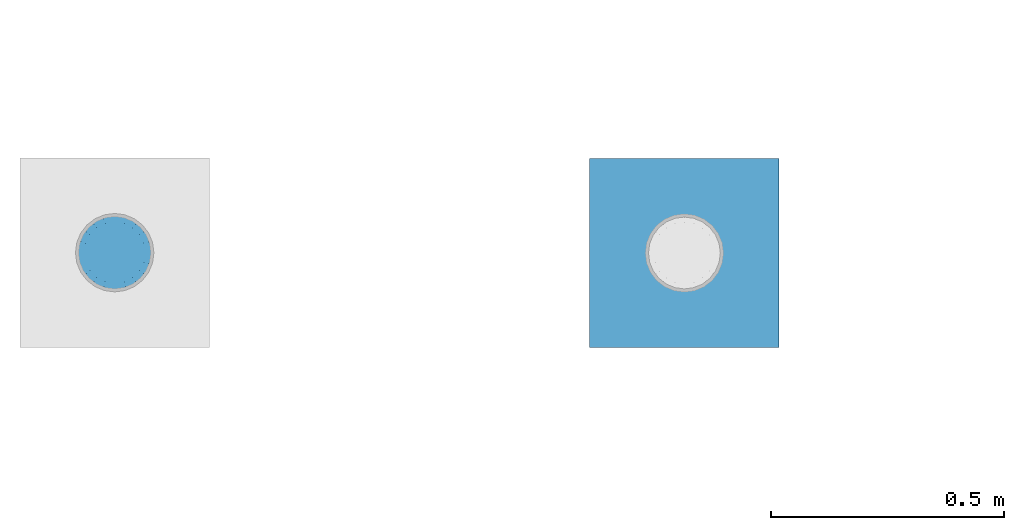
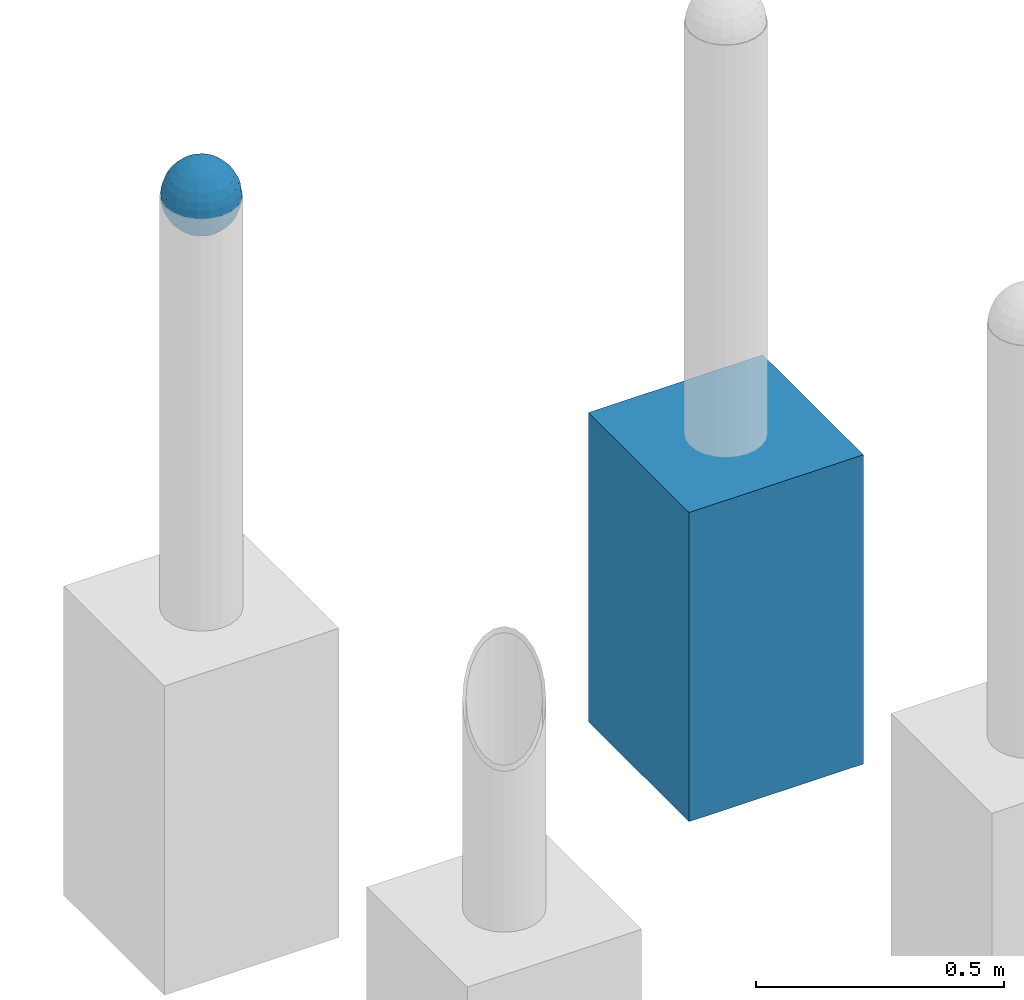
# One storey, part 1434 of 3843: 2 columns, 2 elements without a shape of their own.
"""IFC2X3 building model written with IfcOpenShell, lengths in millimetres."""

import ifcopenshell
import ifcopenshell.guid

model = None  # the IFC model being written
_history = None  # IfcOwnerHistory: only IFC2X3 demands one
_inside = {}  # id of a spatial element -> (the spatial element, [elements in it])
_under = {}  # id of a project, library or spatial element -> (it, [spatial elements below it])
_declared = {}  # id of a project -> (the project, [libraries it declares])
_typed = {}  # id of a type object -> (the type object, [elements of that type])
_made_of = {}  # id of a material, layer set ... -> (it, [elements and type objects made of it])


def new_model(schema):
    """Start an empty IFC model of exactly this schema.

    Asked for "IFC4X3", IfcOpenShell would pick the latest addendum, in which some entities
    have other attributes; the version numbers below select the first issue.
    IFC2X3 requires an IfcOwnerHistory on every rooted entity: one is made here for all.
    """
    global model, _history
    if schema == "IFC4X3":
        model = ifcopenshell.file(schema_version=(4, 3, 0, 0))
    else:
        model = ifcopenshell.file(schema=schema)
    _inside.clear()
    _under.clear()
    _declared.clear()
    _typed.clear()
    _made_of.clear()
    _history = None
    if model.schema == "IFC2X3":
        org = make("IfcOrganization", Name="unknown")
        user = make(
            "IfcPersonAndOrganization",
            ThePerson=make("IfcPerson", FamilyName="unknown"),
            TheOrganization=org,
        )
        app = make(
            "IfcApplication",
            ApplicationDeveloper=org,
            Version="unknown",
            ApplicationFullName="unknown",
            ApplicationIdentifier="unknown",
        )
        _history = make(
            "IfcOwnerHistory",
            OwningUser=user,
            OwningApplication=app,
            ChangeAction="ADDED",
            CreationDate=0,
        )
    return model


def make(cls, **values):
    """One entity of the class cls with the attributes given. An attribute that is None is left unset."""
    return model.create_entity(
        cls, **{name: value for name, value in values.items() if value is not None}
    )


def rooted(cls, **values):
    """An entity with a GlobalId (a new one), such as an element, a storey or a relation."""
    return make(cls, GlobalId=ifcopenshell.guid.new(), OwnerHistory=_history, **values)


def si_unit(unit_type, name, prefix=None):
    """IfcSIUnit, for example si_unit("LENGTHUNIT", "METRE", prefix="MILLI")."""
    return make("IfcSIUnit", UnitType=unit_type, Prefix=prefix, Name=name)


def assignment(units):
    """IfcUnitAssignment: the units of a project."""
    return None if units is None else make("IfcUnitAssignment", Units=units)


def point(xyz):
    """IfcCartesianPoint."""
    return None if xyz is None else make("IfcCartesianPoint", Coordinates=xyz)


def direction(xyz):
    """IfcDirection."""
    return None if xyz is None else make("IfcDirection", DirectionRatios=xyz)


def frame(location, z_axis=None, x_axis=None):
    """IfcAxis2Placement3D, a coordinate frame: its origin and axes. An axis left out is left unset."""
    return make(
        "IfcAxis2Placement3D",
        Location=point(location),
        Axis=direction(z_axis),
        RefDirection=direction(x_axis),
    )


def origin_with_axes():
    """The frame at (0, 0, 0) with the z axis (0, 0, 1) and the x axis (1, 0, 0) written out."""
    return frame((0.0, 0.0, 0.0), z_axis=(0.0, 0.0, 1.0), x_axis=(1.0, 0.0, 0.0))


def place(relative_to, where):
    """IfcLocalPlacement: puts the frame where relative to a parent placement (None: the world)."""
    return make(
        "IfcLocalPlacement", PlacementRelTo=relative_to, RelativePlacement=where
    )


def context(
    kind, dimensions, precision=None, world=None, true_north=None, identifier=None
):
    """IfcGeometricRepresentationContext, for example the 3D "Model" context."""
    return make(
        "IfcGeometricRepresentationContext",
        ContextIdentifier=identifier,
        ContextType=kind,
        CoordinateSpaceDimension=dimensions,
        Precision=precision,
        WorldCoordinateSystem=world,
        TrueNorth=true_north,
    )


def subcontext(parent, identifier, kind, view, scale=None):
    """IfcGeometricRepresentationSubContext, for example "Body" below "Model"."""
    return make(
        "IfcGeometricRepresentationSubContext",
        ContextIdentifier=identifier,
        ContextType=kind,
        ParentContext=parent,
        TargetScale=scale,
        TargetView=view,
    )


def project(units=None, contexts=None):
    """IfcProject with its units and contexts."""
    return rooted(
        "IfcProject",
        Name="project",
        RepresentationContexts=contexts,
        UnitsInContext=assignment(units),
    )


def spatial(cls, under=None, at=None, **own):
    """A site, building, storey or space (cls), placed at a placement, below another one or the project."""
    s = rooted(cls, ObjectPlacement=at, **own)
    if under is not None:
        _under.setdefault(under.id(), (under, []))[1].append(s)
    return s


def faces_of(points, faces, orient=None, outer=None):
    """IfcFace entities. A face is a list of loops; a loop is a list of indices into points, from 0.

    orient and outer hold one flag for each loop. By default every Orientation is true, the
    first loop of a face is its IfcFaceOuterBound and the others are IfcFaceBound.
    """
    made = []
    for i, loops in enumerate(faces):
        bounds = []
        for j, loop in enumerate(loops):
            is_outer = j == 0 if outer is None else outer[i][j]
            bounds.append(
                make(
                    "IfcFaceOuterBound" if is_outer else "IfcFaceBound",
                    Bound=make("IfcPolyLoop", Polygon=[points[k] for k in loop]),
                    Orientation=True if orient is None else orient[i][j],
                )
            )
        made.append(make("IfcFace", Bounds=bounds))
    return made


def faceted_brep(points, faces, orient=None, outer=None, voids=None):
    """IfcFacetedBrep: a solid bounded by flat faces; with voids (closed shells), ...WithVoids."""
    shared = [point(p) for p in points]
    hull = make("IfcClosedShell", CfsFaces=faces_of(shared, faces, orient, outer))
    if voids is None:
        return make("IfcFacetedBrep", Outer=hull)
    return make(
        "IfcFacetedBrepWithVoids",
        Outer=hull,
        Voids=[
            make(cls, CfsFaces=faces_of(shared, fs, o, b)) for cls, fs, o, b in voids
        ],
    )


def shape(context_of_items, identifier, shape_type, items):
    """IfcShapeRepresentation: the items that make up one representation, for example the "Body"."""
    return make(
        "IfcShapeRepresentation",
        ContextOfItems=context_of_items,
        RepresentationIdentifier=identifier,
        RepresentationType=shape_type,
        Items=items,
    )


def material(Name=None, Category=None):
    """IfcMaterial."""
    return make("IfcMaterial", Name=Name, Category=Category)


def made_of(thing, what):
    """Note that an element or type object is made of a material, layer set ...; save() writes the relation."""
    if what is not None:
        _made_of.setdefault(what.id(), (what, []))[1].append(thing)
    return thing


def type_object(cls, material=None, **own):
    """A type object (cls), such as IfcWallType, which elements share."""
    return made_of(rooted(cls, **own), material)


def element(
    cls,
    number,
    at=None,
    inside=None,
    cuts=None,
    type_object=None,
    material=None,
    context=None,
    identifier="Body",
    shape_type=None,
    held_by="IfcProductDefinitionShape",
    body=None,
    shapes=None,
    **own,
):
    """One element of the class cls, such as IfcWall. Its Tag is "e" and its number.

    at: its placement. inside: the storey or other place that contains it. cuts: it is an
    opening in that element (IfcRelVoidsElement). A single representation is given by context,
    identifier, shape_type and body (its items); several are given by shapes. held_by: the class
    of the entity that holds the representations. save() writes the other relations.
    """
    e = rooted(cls, Tag="e%d" % number, ObjectPlacement=at, **own)
    if body is not None:
        shapes = [shape(context, identifier, shape_type, body)]
    if shapes is not None:
        e.Representation = make(held_by, Representations=shapes)
    if inside is not None:
        _inside.setdefault(inside.id(), (inside, []))[1].append(e)
    if cuts is not None:
        rooted(
            "IfcRelVoidsElement", RelatingBuildingElement=cuts, RelatedOpeningElement=e
        )
    if type_object is not None:
        _typed.setdefault(type_object.id(), (type_object, []))[1].append(e)
    return made_of(e, material)


def aggregate(whole, parts):
    """IfcRelAggregates: a whole, such as a stair, and the parts it consists of."""
    return rooted("IfcRelAggregates", RelatingObject=whole, RelatedObjects=parts)


def save(model, path):
    """Write the relations noted so far, then the file.

    IfcRelAggregates (storeys below a building ...), IfcRelContainedInSpatialStructure (elements
    in a storey), IfcRelDefinesByType, IfcRelAssociatesMaterial and IfcRelDeclares: one each for
    every whole, place, type object, material and project.
    """
    for whole, parts in _under.values():
        aggregate(whole, parts)
    for where, things in _inside.values():
        rooted(
            "IfcRelContainedInSpatialStructure",
            RelatedElements=things,
            RelatingStructure=where,
        )
    for kind, things in _typed.values():
        rooted("IfcRelDefinesByType", RelatedObjects=things, RelatingType=kind)
    for what, things in _made_of.values():
        rooted("IfcRelAssociatesMaterial", RelatedObjects=things, RelatingMaterial=what)
    for by, libraries in _declared.values():
        rooted("IfcRelDeclares", RelatingContext=by, RelatedDefinitions=libraries)
    model.write(path)


model = new_model("IFC2X3")

# Units and contexts
model_context = context("Model", 3, precision=1e-05, world=origin_with_axes())
body_context = subcontext(model_context, "Body", "Model", "MODEL_VIEW")
ifc_project = project(units=[si_unit("LENGTHUNIT", "METRE", prefix="MILLI"), si_unit("AREAUNIT", "SQUARE_METRE"), si_unit("VOLUMEUNIT", "CUBIC_METRE"), si_unit("MASSUNIT", "GRAM", prefix="KILO"), si_unit("TIMEUNIT", "SECOND"), si_unit("PLANEANGLEUNIT", "RADIAN"), si_unit("SOLIDANGLEUNIT", "STERADIAN"), si_unit("THERMODYNAMICTEMPERATUREUNIT", "DEGREE_CELSIUS"), si_unit("LUMINOUSINTENSITYUNIT", "LUMEN")], contexts=[model_context])

# Site, building, storey
site_placement = place(None, origin_with_axes())
site = spatial("IfcSite", under=ifc_project, at=site_placement, CompositionType="ELEMENT")
building_placement = place(site_placement, origin_with_axes())
building = spatial("IfcBuilding", under=site, at=building_placement, Name="Undefined", CompositionType="ELEMENT")
storey_placement = place(building_placement, origin_with_axes())
storey = spatial("IfcBuildingStorey", under=building, at=storey_placement, Name="Undefined", CompositionType="ELEMENT", Elevation=0.0)

# Assembly, column
assembly_1_placement = place(storey_placement, origin_with_axes())
assembly_1 = element("IfcElementAssembly", 1, at=assembly_1_placement, inside=storey, Name="CONC_COL.", AssemblyPlace="NOTDEFINED", PredefinedType="REINFORCEMENT_UNIT")
ifc_material_1 = material(Name="CONCRETE/3000")
column_type_1 = type_object("IfcColumnType", PredefinedType="NOTDEFINED")
column_1_placement = place(assembly_1_placement, frame((-49323.3890688121, 17455.2500917911, 29718.0), z_axis=(-1.0, 0.0, 0.0), x_axis=(0.0, 0.0, 1.0)))
column_1 = element("IfcColumn", 2, at=column_1_placement, type_object=column_type_1, material=ifc_material_1, Name="CONC_COL.", context=body_context, shape_type="Brep", body=[
    faceted_brep([(0.0, 203.199999999997, -203.200000000001), (0.0, 203.199999999997, 203.200000000001), (762.0, 203.199999999997, 203.200000000001), (762.0, 203.199999999997, -203.200000000001), (0.0, -203.199999999997, 203.200000000001), (762.0, -203.199999999997, 203.200000000001), (0.0, -203.199999999997, -203.200000000001), (762.0, -203.199999999997, -203.200000000001)], [[[0, 1, 2, 3]], [[1, 4, 5, 2]], [[4, 6, 7, 5]], [[6, 0, 3, 7]], [[5, 7, 3, 2]], [[6, 4, 1, 0]]]),
])
aggregate(assembly_1, [column_1])

assembly_2_placement = place(storey_placement, origin_with_axes())
assembly_2 = element("IfcElementAssembly", 3, at=assembly_2_placement, inside=storey, Name="CONC. FILL", AssemblyPlace="NOTDEFINED", PredefinedType="REINFORCEMENT_UNIT")
ifc_material_2 = material(Name="CONCRETE/1500")
column_type_2 = type_object("IfcColumnType", PredefinedType="NOTDEFINED")
column_2_placement = place(assembly_2_placement, frame((-50545.9919130504, 17455.9024050236, 31411.8625), z_axis=(-1.0, 0.0, 0.0), x_axis=(0.0, 0.0, 1.0)))
column_2 = element("IfcColumn", 4, at=column_2_placement, type_object=column_type_2, material=ifc_material_2, Name="CONC. FILL", context=body_context, shape_type="Brep", body=[
    faceted_brep([(0.0, 0.0, 2.0), (0.0, -0.619999999995343, 1.89999999999964), (3.36549999999988, -7.1422259999963, 21.9814139999999), (3.36549999999988, 0.0, 23.1139999999996), (0.0, -1.17999999999302, 1.6200000000008), (3.36549999999988, -13.5910319999966, 18.6992260000006), (0.0, -1.61999999999534, 1.18000000000029), (3.36549999999988, -18.699225999997, 13.5910320000003), (0.0, -1.89999999999418, 0.6200000000008), (3.36549999999988, -21.9814139999944, 7.14222599999994), (0.0, -2.0, 0.0), (3.36549999999988, -23.1140000000014, 0.0), (0.0, -1.89999999999418, -0.6200000000008), (3.36549999999988, -21.9814139999944, -7.14222599999994), (0.0, -1.61999999999534, -1.18000000000029), (3.36549999999988, -18.699225999997, -13.5910320000003), (0.0, -1.17999999999302, -1.6200000000008), (3.36549999999988, -13.5910319999966, -18.6992260000006), (0.0, -0.619999999995343, -1.89999999999964), (3.36549999999988, -7.1422259999963, -21.9814139999999), (0.0, 0.0, -2.0), (3.36549999999988, 0.0, -23.1139999999996), (0.0, 0.619999999995343, -1.89999999999964), (3.36549999999988, 7.1422259999963, -21.9814139999999), (0.0, 1.17999999999302, -1.6200000000008), (3.36549999999988, 13.5910319999966, -18.6992260000006), (0.0, 1.61999999999534, -1.18000000000029), (3.36549999999988, 18.699225999997, -13.5910320000003), (0.0, 1.89999999999418, -0.6200000000008), (3.36549999999988, 21.9814139999944, -7.14222599999994), (0.0, 2.0, 0.0), (3.36549999999988, 23.1140000000014, 0.0), (0.0, 1.89999999999418, 0.6200000000008), (3.36549999999988, 21.9814139999944, 7.14222599999994), (0.0, 1.61999999999534, 1.18000000000029), (3.36549999999988, 18.699225999997, 13.5910320000003), (0.0, 1.17999999999302, 1.6200000000008), (3.36549999999988, 13.5910319999966, 18.6992260000006), (0.0, 0.619999999995343, 1.89999999999964), (3.36549999999988, 7.1422259999963, 21.9814139999999), (8.41374999999971, -11.1214661999984, 34.2282018000005), (8.41374999999971, 0.0, 35.9917999999998), (8.41374999999971, -21.1631784000056, 29.1173662000001), (8.41374999999971, -29.1173661999928, 21.1631784000001), (8.41374999999971, -34.2282017999969, 11.1214662000002), (8.41374999999971, -35.9918000000034, 0.0), (8.41374999999971, -34.2282017999969, -11.1214662000002), (8.41374999999971, -29.1173661999928, -21.1631784000001), (8.41374999999971, -21.1631784000056, -29.1173662000001), (8.41374999999971, -11.1214661999984, -34.2282018000005), (8.41374999999971, 0.0, -35.9917999999998), (8.41374999999971, 11.1214661999984, -34.2282018000005), (8.41374999999971, 21.1631784000056, -29.1173662000001), (8.41374999999971, 29.1173661999928, -21.1631784000001), (8.41374999999971, 34.2282017999969, -11.1214662000002), (8.41374999999971, 35.9918000000034, 0.0), (8.41374999999971, 34.2282017999969, 11.1214662000002), (8.41374999999971, 29.1173661999928, 21.1631784000001), (8.41374999999971, 21.1631784000056, 29.1173662000001), (8.41374999999971, 11.1214661999984, 34.2282018000005), (16.8274999999994, -15.3047700000025, 47.1030300000002), (16.8274999999994, 0.0, 49.5300000000007), (16.8274999999994, -29.1236400000053, 40.0697700000001), (16.8274999999994, -40.0697700000019, 29.1236399999998), (16.8274999999994, -47.1030299999984, 15.3047700000006), (16.8274999999994, -49.5299999999988, 0.0), (16.8274999999994, -47.1030299999984, -15.3047700000006), (16.8274999999994, -40.0697700000019, -29.1236399999998), (16.8274999999994, -29.1236400000053, -40.0697700000001), (16.8274999999994, -15.3047700000025, -47.1030300000002), (16.8274999999994, 0.0, -49.5300000000007), (16.8274999999994, 15.3047700000025, -47.1030300000002), (16.8274999999994, 29.1236400000053, -40.0697700000001), (16.8274999999994, 40.0697700000019, -29.1236399999998), (16.8274999999994, 47.1030299999984, -15.3047700000006), (16.8274999999994, 49.5299999999988, 0.0), (16.8274999999994, 47.1030299999984, 15.3047700000006), (16.8274999999994, 40.0697700000019, 29.1236399999998), (16.8274999999994, 29.1236400000053, 40.0697700000001), (16.8274999999994, 15.3047700000025, 47.1030300000002), (33.6549999999988, -20.4063599999936, 62.8040400000009), (33.6549999999988, 0.0, 66.0400000000009), (33.6549999999988, -38.831520000007, 53.4263599999995), (33.6549999999988, -53.4263599999977, 38.8315199999997), (33.6549999999988, -62.8040400000027, 20.4063600000009), (33.6549999999988, -66.0399999999936, 0.0), (33.6549999999988, -62.8040400000027, -20.4063600000009), (33.6549999999988, -53.4263599999977, -38.8315199999997), (33.6549999999988, -38.831520000007, -53.4263599999995), (33.6549999999988, -20.4063599999936, -62.8040400000009), (33.6549999999988, 0.0, -66.0400000000009), (33.6549999999988, 20.4063599999936, -62.8040400000009), (33.6549999999988, 38.831520000007, -53.4263599999995), (33.6549999999988, 53.4263599999977, -38.8315199999997), (33.6549999999988, 62.8040400000027, -20.4063600000009), (33.6549999999988, 66.0399999999936, 0.0), (33.6549999999988, 62.8040400000027, 20.4063600000009), (33.6549999999988, 53.4263599999977, 38.8315199999997), (33.6549999999988, 38.831520000007, 53.4263599999995), (33.6549999999988, 20.4063599999936, 62.8040400000009), (50.4824999999983, -23.3907901500061, 71.9891308499991), (50.4824999999983, 0.0, 75.6983500000006), (50.4824999999983, -44.5106298000028, 61.23996515), (50.4824999999983, -61.2399651500018, 44.5106297999992), (50.4824999999983, -71.9891308499937, 23.3907901500006), (50.4824999999983, -75.698350000006, 0.0), (50.4824999999983, -71.9891308499937, -23.3907901500006), (50.4824999999983, -61.2399651500018, -44.5106297999992), (50.4824999999983, -44.5106298000028, -61.23996515), (50.4824999999983, -23.3907901500061, -71.9891308499991), (50.4824999999983, 0.0, -75.6983500000006), (50.4824999999983, 23.3907901500061, -71.9891308499991), (50.4824999999983, 44.5106298000028, -61.23996515), (50.4824999999983, 61.2399651500018, -44.5106297999992), (50.4824999999983, 71.9891308499937, -23.3907901500006), (50.4824999999983, 75.698350000006, 0.0), (50.4824999999983, 71.9891308499937, 23.3907901500006), (50.4824999999983, 61.2399651500018, 44.5106297999992), (50.4824999999983, 44.5106298000028, 61.23996515), (50.4824999999983, 23.3907901500061, 71.9891308499991), (67.3099999999977, -24.9977910000016, 76.9349490000004), (67.3099999999977, 0.0, 80.8989999999994), (67.3099999999977, -47.5686120000028, 65.4472910000004), (67.3099999999977, -65.447291000004, 47.5686119999991), (67.3099999999977, -76.9349490000022, 24.9977909999998), (67.3099999999977, -80.8990000000049, 0.0), (67.3099999999977, -76.9349490000022, -24.9977909999998), (67.3099999999977, -65.447291000004, -47.5686119999991), (67.3099999999977, -47.5686120000028, -65.4472910000004), (67.3099999999977, -24.9977910000016, -76.9349490000004), (67.3099999999977, 0.0, -80.8989999999994), (67.3099999999977, 24.9977910000016, -76.9349490000004), (67.3099999999977, 47.5686120000028, -65.4472910000004), (67.3099999999977, 65.447291000004, -47.5686119999991), (67.3099999999977, 76.9349490000022, -24.9977909999998), (67.3099999999977, 80.8990000000049, 0.0), (67.3099999999977, 76.9349490000022, 24.9977909999998), (67.3099999999977, 65.447291000004, 47.5686119999991), (67.3099999999977, 47.5686120000028, 65.4472910000004), (67.3099999999977, 24.9977910000016, 76.9349490000004), (84.1374999999935, -25.5079499999993, 78.5050499999998), (84.1374999999935, 0.0, 82.5499999999993), (84.1374999999935, -48.5393999999942, 66.7829500000007), (84.1374999999935, -66.7829499999934, 48.5393999999997), (84.1374999999935, -78.505050000007, 25.5079499999993), (84.1374999999935, -82.5500000000029, 0.0), (84.1374999999935, -78.505050000007, -25.5079499999993), (84.1374999999935, -66.7829499999934, -48.5393999999997), (84.1374999999935, -48.5393999999942, -66.7829500000007), (84.1374999999935, -25.5079499999993, -78.5050499999998), (84.1374999999935, 0.0, -82.5499999999993), (84.1374999999935, 25.5079499999993, -78.5050499999998), (84.1374999999935, 48.5393999999942, -66.7829500000007), (84.1374999999935, 66.7829499999934, -48.5393999999997), (84.1374999999935, 78.505050000007, -25.5079499999993), (84.1374999999935, 82.5500000000029, 0.0), (84.1374999999935, 78.505050000007, 25.5079499999993), (84.1374999999935, 66.7829499999934, 48.5393999999997), (84.1374999999935, 48.5393999999942, 66.7829500000007), (84.1374999999935, 25.5079499999993, 78.5050499999998), (100.964999999993, -24.9977910000016, 76.9349490000004), (100.964999999993, 0.0, 80.8989999999994), (100.964999999993, -47.5686120000028, 65.4472910000004), (100.964999999993, -65.447291000004, 47.5686119999991), (100.964999999993, -76.9349490000022, 24.9977909999998), (100.964999999993, -80.8990000000049, 0.0), (100.964999999993, -76.9349490000022, -24.9977909999998), (100.964999999993, -65.447291000004, -47.5686119999991), (100.964999999993, -47.5686120000028, -65.4472910000004), (100.964999999993, -24.9977910000016, -76.9349490000004), (100.964999999993, 0.0, -80.8989999999994), (100.964999999993, 24.9977910000016, -76.9349490000004), (100.964999999993, 47.5686120000028, -65.4472910000004), (100.964999999993, 65.447291000004, -47.5686119999991), (100.964999999993, 76.9349490000022, -24.9977909999998), (100.964999999993, 80.8990000000049, 0.0), (100.964999999993, 76.9349490000022, 24.9977909999998), (100.964999999993, 65.447291000004, 47.5686119999991), (100.964999999993, 47.5686120000028, 65.4472910000004), (100.964999999993, 24.9977910000016, 76.9349490000004), (117.792499999992, -23.3907901500061, 71.9891308499991), (117.792499999992, 0.0, 75.6983500000006), (117.792499999992, -44.5106298000028, 61.23996515), (117.792499999992, -61.2399651500018, 44.5106297999992), (117.792499999992, -71.9891308499937, 23.3907901500006), (117.792499999992, -75.698350000006, 0.0), (117.792499999992, -71.9891308499937, -23.3907901500006), (117.792499999992, -61.2399651500018, -44.5106297999992), (117.792499999992, -44.5106298000028, -61.23996515), (117.792499999992, -23.3907901500061, -71.9891308499991), (117.792499999992, 0.0, -75.6983500000006), (117.792499999992, 23.3907901500061, -71.9891308499991), (117.792499999992, 44.5106298000028, -61.23996515), (117.792499999992, 61.2399651500018, -44.5106297999992), (117.792499999992, 71.9891308499937, -23.3907901500006), (117.792499999992, 75.698350000006, 0.0), (117.792499999992, 71.9891308499937, 23.3907901500006), (117.792499999992, 61.2399651500018, 44.5106297999992), (117.792499999992, 44.5106298000028, 61.23996515), (117.792499999992, 23.3907901500061, 71.9891308499991), (134.619999999992, -20.4063599999936, 62.8040400000009), (134.619999999992, 0.0, 66.0400000000009), (134.619999999992, -38.831520000007, 53.4263599999995), (134.619999999992, -53.4263599999977, 38.8315199999997), (134.619999999992, -62.8040400000027, 20.4063600000009), (134.619999999992, -66.0399999999936, 0.0), (134.619999999992, -62.8040400000027, -20.4063600000009), (134.619999999992, -53.4263599999977, -38.8315199999997), (134.619999999992, -38.831520000007, -53.4263599999995), (134.619999999992, -20.4063599999936, -62.8040400000009), (134.619999999992, 0.0, -66.0400000000009), (134.619999999992, 20.4063599999936, -62.8040400000009), (134.619999999992, 38.831520000007, -53.4263599999995), (134.619999999992, 53.4263599999977, -38.8315199999997), (134.619999999992, 62.8040400000027, -20.4063600000009), (134.619999999992, 66.0399999999936, 0.0), (134.619999999992, 62.8040400000027, 20.4063600000009), (134.619999999992, 53.4263599999977, 38.8315199999997), (134.619999999992, 38.831520000007, 53.4263599999995), (134.619999999992, 20.4063599999936, 62.8040400000009), (151.447499999991, -15.3047700000025, 47.1030300000002), (151.447499999991, 0.0, 49.5300000000007), (151.447499999991, -29.1236400000053, 40.0697700000001), (151.447499999991, -40.0697700000019, 29.1236399999998), (151.447499999991, -47.1030299999984, 15.3047700000006), (151.447499999991, -49.5299999999988, 0.0), (151.447499999991, -47.1030299999984, -15.3047700000006), (151.447499999991, -40.0697700000019, -29.1236399999998), (151.447499999991, -29.1236400000053, -40.0697700000001), (151.447499999991, -15.3047700000025, -47.1030300000002), (151.447499999991, 0.0, -49.5300000000007), (151.447499999991, 15.3047700000025, -47.1030300000002), (151.447499999991, 29.1236400000053, -40.0697700000001), (151.447499999991, 40.0697700000019, -29.1236399999998), (151.447499999991, 47.1030299999984, -15.3047700000006), (151.447499999991, 49.5299999999988, 0.0), (151.447499999991, 47.1030299999984, 15.3047700000006), (151.447499999991, 40.0697700000019, 29.1236399999998), (151.447499999991, 29.1236400000053, 40.0697700000001), (151.447499999991, 15.3047700000025, 47.1030300000002), (159.861249999991, -11.1214661999984, 34.2282018000005), (159.861249999991, 0.0, 35.9917999999998), (159.861249999991, -21.1631784000056, 29.1173662000001), (159.861249999991, -29.1173661999928, 21.1631784000001), (159.861249999991, -34.2282017999969, 11.1214662000002), (159.861249999991, -35.9918000000034, 0.0), (159.861249999991, -34.2282017999969, -11.1214662000002), (159.861249999991, -29.1173661999928, -21.1631784000001), (159.861249999991, -21.1631784000056, -29.1173662000001), (159.861249999991, -11.1214661999984, -34.2282018000005), (159.861249999991, 0.0, -35.9917999999998), (159.861249999991, 11.1214661999984, -34.2282018000005), (159.861249999991, 21.1631784000056, -29.1173662000001), (159.861249999991, 29.1173661999928, -21.1631784000001), (159.861249999991, 34.2282017999969, -11.1214662000002), (159.861249999991, 35.9918000000034, 0.0), (159.861249999991, 34.2282017999969, 11.1214662000002), (159.861249999991, 29.1173661999928, 21.1631784000001), (159.861249999991, 21.1631784000056, 29.1173662000001), (159.861249999991, 11.1214661999984, 34.2282018000005), (164.909499999991, -7.1422259999963, 21.9814139999999), (164.909499999991, 0.0, 23.1139999999996), (164.909499999991, -13.5910319999966, 18.6992260000006), (164.909499999991, -18.699225999997, 13.5910320000003), (164.909499999991, -21.9814139999944, 7.14222599999994), (164.909499999991, -23.1140000000014, 0.0), (164.909499999991, -21.9814139999944, -7.14222599999994), (164.909499999991, -18.699225999997, -13.5910320000003), (164.909499999991, -13.5910319999966, -18.6992260000006), (164.909499999991, -7.1422259999963, -21.9814139999999), (164.909499999991, 0.0, -23.1139999999996), (164.909499999991, 7.1422259999963, -21.9814139999999), (164.909499999991, 13.5910319999966, -18.6992260000006), (164.909499999991, 18.699225999997, -13.5910320000003), (164.909499999991, 21.9814139999944, -7.14222599999994), (164.909499999991, 23.1140000000014, 0.0), (164.909499999991, 21.9814139999944, 7.14222599999994), (164.909499999991, 18.699225999997, 13.5910320000003), (164.909499999991, 13.5910319999966, 18.6992260000006), (164.909499999991, 7.1422259999963, 21.9814139999999), (168.274999999991, -0.619999999995343, 1.89999999999964), (168.274999999991, 0.0, 2.0), (168.274999999991, -1.17999999999302, 1.6200000000008), (168.274999999991, -1.61999999999534, 1.18000000000029), (168.274999999991, -1.89999999999418, 0.6200000000008), (168.274999999991, -2.0, 0.0), (168.274999999991, -1.89999999999418, -0.6200000000008), (168.274999999991, -1.61999999999534, -1.18000000000029), (168.274999999991, -1.17999999999302, -1.6200000000008), (168.274999999991, -0.619999999995343, -1.89999999999964), (168.274999999991, 0.0, -2.0), (168.274999999991, 0.619999999995343, -1.89999999999964), (168.274999999991, 1.17999999999302, -1.6200000000008), (168.274999999991, 1.61999999999534, -1.18000000000029), (168.274999999991, 1.89999999999418, -0.6200000000008), (168.274999999991, 2.0, 0.0), (168.274999999991, 1.89999999999418, 0.6200000000008), (168.274999999991, 1.61999999999534, 1.18000000000029), (168.274999999991, 1.17999999999302, 1.6200000000008), (168.274999999991, 0.619999999995343, 1.89999999999964)], [[[0, 1, 2, 3]], [[1, 4, 5, 2]], [[4, 6, 7, 5]], [[6, 8, 9, 7]], [[8, 10, 11, 9]], [[10, 12, 13, 11]], [[12, 14, 15, 13]], [[14, 16, 17, 15]], [[16, 18, 19, 17]], [[18, 20, 21, 19]], [[20, 22, 23, 21]], [[22, 24, 25, 23]], [[24, 26, 27, 25]], [[26, 28, 29, 27]], [[28, 30, 31, 29]], [[30, 32, 33, 31]], [[32, 34, 35, 33]], [[34, 36, 37, 35]], [[36, 38, 39, 37]], [[38, 0, 3, 39]], [[38, 36, 34, 32, 30, 28, 26, 24, 22, 20, 18, 16, 14, 12, 10, 8, 6, 4, 1, 0]], [[3, 2, 40, 41]], [[2, 5, 42, 40]], [[5, 7, 43, 42]], [[7, 9, 44, 43]], [[9, 11, 45, 44]], [[11, 13, 46, 45]], [[13, 15, 47, 46]], [[15, 17, 48, 47]], [[17, 19, 49, 48]], [[19, 21, 50, 49]], [[21, 23, 51, 50]], [[23, 25, 52, 51]], [[25, 27, 53, 52]], [[27, 29, 54, 53]], [[29, 31, 55, 54]], [[31, 33, 56, 55]], [[33, 35, 57, 56]], [[35, 37, 58, 57]], [[37, 39, 59, 58]], [[39, 3, 41, 59]], [[41, 40, 60, 61]], [[40, 42, 62, 60]], [[42, 43, 63, 62]], [[43, 44, 64, 63]], [[44, 45, 65, 64]], [[45, 46, 66, 65]], [[46, 47, 67, 66]], [[47, 48, 68, 67]], [[48, 49, 69, 68]], [[49, 50, 70, 69]], [[50, 51, 71, 70]], [[51, 52, 72, 71]], [[52, 53, 73, 72]], [[53, 54, 74, 73]], [[54, 55, 75, 74]], [[55, 56, 76, 75]], [[56, 57, 77, 76]], [[57, 58, 78, 77]], [[58, 59, 79, 78]], [[59, 41, 61, 79]], [[61, 60, 80, 81]], [[60, 62, 82, 80]], [[62, 63, 83, 82]], [[63, 64, 84, 83]], [[64, 65, 85, 84]], [[65, 66, 86, 85]], [[66, 67, 87, 86]], [[67, 68, 88, 87]], [[68, 69, 89, 88]], [[69, 70, 90, 89]], [[70, 71, 91, 90]], [[71, 72, 92, 91]], [[72, 73, 93, 92]], [[73, 74, 94, 93]], [[74, 75, 95, 94]], [[75, 76, 96, 95]], [[76, 77, 97, 96]], [[77, 78, 98, 97]], [[78, 79, 99, 98]], [[79, 61, 81, 99]], [[81, 80, 100, 101]], [[80, 82, 102, 100]], [[82, 83, 103, 102]], [[83, 84, 104, 103]], [[84, 85, 105, 104]], [[85, 86, 106, 105]], [[86, 87, 107, 106]], [[87, 88, 108, 107]], [[88, 89, 109, 108]], [[89, 90, 110, 109]], [[90, 91, 111, 110]], [[91, 92, 112, 111]], [[92, 93, 113, 112]], [[93, 94, 114, 113]], [[94, 95, 115, 114]], [[95, 96, 116, 115]], [[96, 97, 117, 116]], [[97, 98, 118, 117]], [[98, 99, 119, 118]], [[99, 81, 101, 119]], [[101, 100, 120, 121]], [[100, 102, 122, 120]], [[102, 103, 123, 122]], [[103, 104, 124, 123]], [[104, 105, 125, 124]], [[105, 106, 126, 125]], [[106, 107, 127, 126]], [[107, 108, 128, 127]], [[108, 109, 129, 128]], [[109, 110, 130, 129]], [[110, 111, 131, 130]], [[111, 112, 132, 131]], [[112, 113, 133, 132]], [[113, 114, 134, 133]], [[114, 115, 135, 134]], [[115, 116, 136, 135]], [[116, 117, 137, 136]], [[117, 118, 138, 137]], [[118, 119, 139, 138]], [[119, 101, 121, 139]], [[121, 120, 140, 141]], [[120, 122, 142, 140]], [[122, 123, 143, 142]], [[123, 124, 144, 143]], [[124, 125, 145, 144]], [[125, 126, 146, 145]], [[126, 127, 147, 146]], [[127, 128, 148, 147]], [[128, 129, 149, 148]], [[129, 130, 150, 149]], [[130, 131, 151, 150]], [[131, 132, 152, 151]], [[132, 133, 153, 152]], [[133, 134, 154, 153]], [[134, 135, 155, 154]], [[135, 136, 156, 155]], [[136, 137, 157, 156]], [[137, 138, 158, 157]], [[138, 139, 159, 158]], [[139, 121, 141, 159]], [[141, 140, 160, 161]], [[140, 142, 162, 160]], [[142, 143, 163, 162]], [[143, 144, 164, 163]], [[144, 145, 165, 164]], [[145, 146, 166, 165]], [[146, 147, 167, 166]], [[147, 148, 168, 167]], [[148, 149, 169, 168]], [[149, 150, 170, 169]], [[150, 151, 171, 170]], [[151, 152, 172, 171]], [[152, 153, 173, 172]], [[153, 154, 174, 173]], [[154, 155, 175, 174]], [[155, 156, 176, 175]], [[156, 157, 177, 176]], [[157, 158, 178, 177]], [[158, 159, 179, 178]], [[159, 141, 161, 179]], [[161, 160, 180, 181]], [[160, 162, 182, 180]], [[162, 163, 183, 182]], [[163, 164, 184, 183]], [[164, 165, 185, 184]], [[165, 166, 186, 185]], [[166, 167, 187, 186]], [[167, 168, 188, 187]], [[168, 169, 189, 188]], [[169, 170, 190, 189]], [[170, 171, 191, 190]], [[171, 172, 192, 191]], [[172, 173, 193, 192]], [[173, 174, 194, 193]], [[174, 175, 195, 194]], [[175, 176, 196, 195]], [[176, 177, 197, 196]], [[177, 178, 198, 197]], [[178, 179, 199, 198]], [[179, 161, 181, 199]], [[181, 180, 200, 201]], [[180, 182, 202, 200]], [[182, 183, 203, 202]], [[183, 184, 204, 203]], [[184, 185, 205, 204]], [[185, 186, 206, 205]], [[186, 187, 207, 206]], [[187, 188, 208, 207]], [[188, 189, 209, 208]], [[189, 190, 210, 209]], [[190, 191, 211, 210]], [[191, 192, 212, 211]], [[192, 193, 213, 212]], [[193, 194, 214, 213]], [[194, 195, 215, 214]], [[195, 196, 216, 215]], [[196, 197, 217, 216]], [[197, 198, 218, 217]], [[198, 199, 219, 218]], [[199, 181, 201, 219]], [[201, 200, 220, 221]], [[200, 202, 222, 220]], [[202, 203, 223, 222]], [[203, 204, 224, 223]], [[204, 205, 225, 224]], [[205, 206, 226, 225]], [[206, 207, 227, 226]], [[207, 208, 228, 227]], [[208, 209, 229, 228]], [[209, 210, 230, 229]], [[210, 211, 231, 230]], [[211, 212, 232, 231]], [[212, 213, 233, 232]], [[213, 214, 234, 233]], [[214, 215, 235, 234]], [[215, 216, 236, 235]], [[216, 217, 237, 236]], [[217, 218, 238, 237]], [[218, 219, 239, 238]], [[219, 201, 221, 239]], [[221, 220, 240, 241]], [[220, 222, 242, 240]], [[222, 223, 243, 242]], [[223, 224, 244, 243]], [[224, 225, 245, 244]], [[225, 226, 246, 245]], [[226, 227, 247, 246]], [[227, 228, 248, 247]], [[228, 229, 249, 248]], [[229, 230, 250, 249]], [[230, 231, 251, 250]], [[231, 232, 252, 251]], [[232, 233, 253, 252]], [[233, 234, 254, 253]], [[234, 235, 255, 254]], [[235, 236, 256, 255]], [[236, 237, 257, 256]], [[237, 238, 258, 257]], [[238, 239, 259, 258]], [[239, 221, 241, 259]], [[241, 240, 260, 261]], [[240, 242, 262, 260]], [[242, 243, 263, 262]], [[243, 244, 264, 263]], [[244, 245, 265, 264]], [[245, 246, 266, 265]], [[246, 247, 267, 266]], [[247, 248, 268, 267]], [[248, 249, 269, 268]], [[249, 250, 270, 269]], [[250, 251, 271, 270]], [[251, 252, 272, 271]], [[252, 253, 273, 272]], [[253, 254, 274, 273]], [[254, 255, 275, 274]], [[255, 256, 276, 275]], [[256, 257, 277, 276]], [[257, 258, 278, 277]], [[258, 259, 279, 278]], [[259, 241, 261, 279]], [[261, 260, 280, 281]], [[260, 262, 282, 280]], [[262, 263, 283, 282]], [[263, 264, 284, 283]], [[264, 265, 285, 284]], [[265, 266, 286, 285]], [[266, 267, 287, 286]], [[267, 268, 288, 287]], [[268, 269, 289, 288]], [[269, 270, 290, 289]], [[270, 271, 291, 290]], [[271, 272, 292, 291]], [[272, 273, 293, 292]], [[273, 274, 294, 293]], [[274, 275, 295, 294]], [[275, 276, 296, 295]], [[276, 277, 297, 296]], [[277, 278, 298, 297]], [[278, 279, 299, 298]], [[279, 261, 281, 299]], [[282, 283, 284, 285, 286, 287, 288, 289, 290, 291, 292, 293, 294, 295, 296, 297, 298, 299, 281, 280]]]),
])
aggregate(assembly_2, [column_2])

save(model, "model.ifc")
